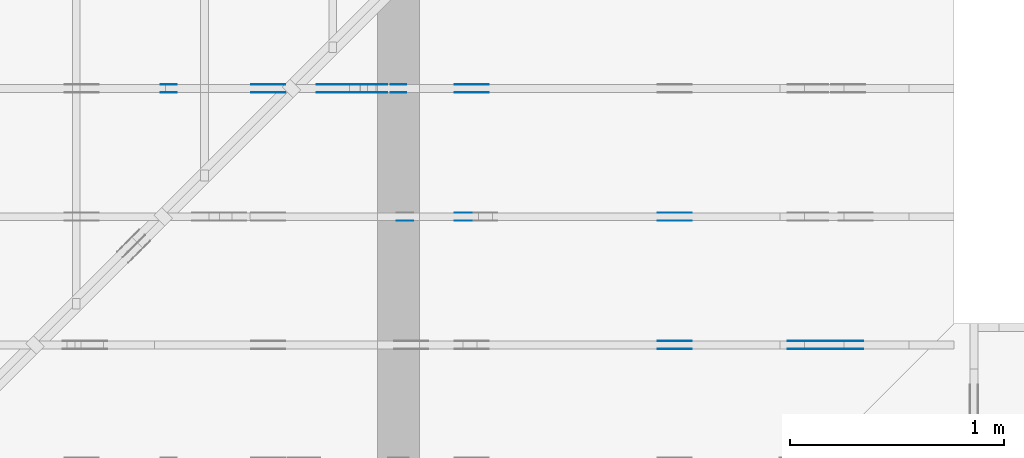
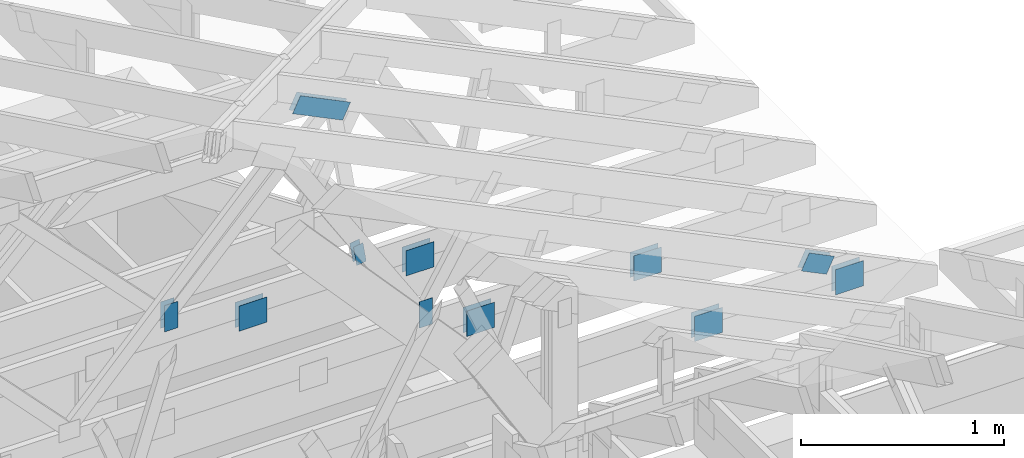
# One storey, part 133 of 159: 21 plates, 3 elements without a shape of their own.
"""IFC2X3 building model written with IfcOpenShell, lengths in millimetres."""

from ifc_helpers import new_model, si_unit, frame, origin, origin_with_axes, origin_2d, place, context, project, spatial, faceted_brep, element, aggregate, save


model = new_model("IFC2X3")

# Units and contexts
model_context = context("Model", 3, precision=1e-05, world=origin())
plan_context = context("Plan", 2, precision=1e-05, world=origin_2d())
ifc_project = project(units=[si_unit("LENGTHUNIT", "METRE", prefix="MILLI"), si_unit("AREAUNIT", "SQUARE_METRE"), si_unit("VOLUMEUNIT", "CUBIC_METRE"), si_unit("SOLIDANGLEUNIT", "STERADIAN"), si_unit("PLANEANGLEUNIT", "RADIAN"), si_unit("MASSUNIT", "GRAM"), si_unit("TIMEUNIT", "SECOND"), si_unit("THERMODYNAMICTEMPERATUREUNIT", "DEGREE_CELSIUS"), si_unit("LUMINOUSINTENSITYUNIT", "LUMEN")], contexts=[model_context, plan_context])

# Site, building, storey
site_placement = place(None, origin_with_axes())
site = spatial("IfcSite", under=ifc_project, at=site_placement, CompositionType="ELEMENT")
building_placement = place(site_placement, origin_with_axes())
building = spatial("IfcBuilding", under=site, at=building_placement, Name="Plan 1", CompositionType="ELEMENT")
storey_placement = place(building_placement, origin_with_axes())
storey = spatial("IfcBuildingStorey", under=building, at=storey_placement, Name="Etasje 1", CompositionType="ELEMENT", Elevation=0.0)

# Assembly, plates
assembly_1_placement = place(storey_placement, frame((19200.01266310149, 9617.999978540158, 1.1021457184401395e-15), z_axis=(1.2246063538223773e-16, 1.0, 6.123031769111886e-17), x_axis=(-1.0, 1.2246063538223773e-16, 0.0)))
assembly_1 = element("IfcElementAssembly", 1, at=assembly_1_placement, inside=storey, Name="V12 (104)", AssemblyPlace="FACTORY", PredefinedType="TRUSS")
plate_1_placement = place(assembly_1_placement, frame((634.5549831590021, 289.86159814155985, 0.0), z_axis=(0.0, 0.0, 1.0), x_axis=(0.8987940462991673, 0.4383711467890768, 0.0)))
plate_1 = element("IfcPlate", 2, at=plate_1_placement, Name="GNT100S 103x159", context=model_context, shape_type="Brep", body=[
    faceted_brep([(159.00002403271037, 102.9999867309898, 1.0), (1.1281355568826257e-05, 102.9999867309898, 1.0), (1.0588386885501677e-05, 0.0, 1.0), (159.0000233397417, 0.0, 1.0), (1.1281355568826257e-05, 102.9999867309898, 1.3815219709314093e-21), (159.00002403271037, 102.9999867309898, 1.947124396883678e-14), (159.0000233397417, 1.5107132753655605e-06, 1.9471243883975396e-14), (1.0588386885501677e-05, 1.5107132753655605e-06, 1.2966605856714886e-21), (159.0, 2.563772084510416e-06, 1.788345407099479e-30), (159.0, 2.5637720845716463e-06, 1.0), (1.1247455413666031e-32, 2.563772113778508e-06, 1.0), (0.0, 2.5637721137172775e-06, 0.0), (159.0, 103.00000256377206, 0.0), (159.0, 103.00000256377206, 1.0), (159.0, 2.5637721137172775e-06, 1.0), (159.0, 2.5637721137172775e-06, 0.0), (0.0, 103.00000256377206, 0.0), (-3.7491518045553436e-33, 103.00000256377206, 1.0), (159.0, 103.00000256377204, 1.0), (159.0, 103.00000256377204, -7.888609052210118e-31), (3.1396116202108044e-22, 2.5637721137172775e-06, -1.9223941693223597e-38), (6.123063165228088e-17, 2.5637721137172775e-06, 1.0), (1.2674676076022759e-14, 103.00000256377206, 1.0), (1.261344575833164e-14, 103.00000256377206, -7.723252909623421e-31)], [[[0, 1, 2, 3]], [[4, 5, 6, 7]], [[8, 9, 10, 11]], [[12, 13, 14, 15]], [[16, 17, 18, 19]], [[20, 21, 22, 23]]]),
])
plate_2_placement = place(assembly_1_placement, frame((634.5549831590021, 289.86159814155985, -37.0), z_axis=(0.0, 0.0, 1.0), x_axis=(0.8987940462991673, 0.4383711467890768, 0.0)))
plate_2 = element("IfcPlate", 3, at=plate_2_placement, Name="GNT100S 103x159", context=model_context, shape_type="Brep", body=[
    faceted_brep([(159.00002403271037, 102.9999867309898, 1.0), (1.1281355568826257e-05, 102.9999867309898, 1.0), (1.0588386885501677e-05, 0.0, 1.0), (159.0000233397417, 0.0, 1.0), (1.1281355568826257e-05, 102.9999867309898, 1.3815219709314093e-21), (159.00002403271037, 102.9999867309898, 1.947124396883678e-14), (159.0000233397417, 1.5107132753655605e-06, 1.9471243883975396e-14), (1.0588386885501677e-05, 1.5107132753655605e-06, 1.2966605856714886e-21), (159.0, 2.563772084510416e-06, 1.788345407099479e-30), (159.0, 2.5637720845716463e-06, 1.0), (1.1247455413666031e-32, 2.563772113778508e-06, 1.0), (0.0, 2.5637721137172775e-06, 0.0), (159.0, 103.00000256377206, 0.0), (159.0, 103.00000256377206, 1.0), (159.0, 2.5637721137172775e-06, 1.0), (159.0, 2.5637721137172775e-06, 0.0), (0.0, 103.00000256377206, 0.0), (-3.7491518045553436e-33, 103.00000256377206, 1.0), (159.0, 103.00000256377204, 1.0), (159.0, 103.00000256377204, -7.888609052210118e-31), (3.1396116202108044e-22, 2.5637721137172775e-06, -1.9223941693223597e-38), (6.123063165228088e-17, 2.5637721137172775e-06, 1.0), (1.2674676076022759e-14, 103.00000256377206, 1.0), (1.261344575833164e-14, 103.00000256377206, -7.723252909623421e-31)], [[[0, 1, 2, 3]], [[4, 5, 6, 7]], [[8, 9, 10, 11]], [[12, 13, 14, 15]], [[16, 17, 18, 19]], [[20, 21, 22, 23]]]),
])
plate_3_placement = place(assembly_1_placement, frame((1226.5269234454372, 147.0, 0.0), z_axis=(0.0, 0.0, 1.0), x_axis=(1.0, 0.0, 0.0)))
plate_3 = element("IfcPlate", 4, at=plate_3_placement, Name="GNT100S 152x159", context=model_context, shape_type="Brep", body=[
    faceted_brep([(159.0000540936253, 152.0, 1.0), (5.409362529462669e-05, 152.0, 1.0), (5.409362529462669e-05, 0.0, 1.0), (159.0000540936253, 0.0, 1.0), (5.409362529462669e-05, 152.0, 6.624339723708671e-21), (159.0000540936253, 152.0, 1.9471247650115523e-14), (159.0000540936253, 0.0, 1.9471247650115523e-14), (5.409362529462669e-05, 0.0, 6.624339723708671e-21), (159.0, 7.024986068391876e-10, 1.788345410772899e-30), (159.0, 7.024986680695053e-10, 1.0), (1.1247455413666031e-32, 7.025278749310439e-10, 1.0), (0.0, 7.025278137007263e-10, 0.0), (159.0, 152.00000000070253, 0.0), (159.0, 152.00000000070253, 1.0), (159.0, 7.025278137007263e-10, 1.0), (159.0, 7.025278137007263e-10, 0.0), (0.0, 152.00000000070253, 0.0), (-3.7491518045553436e-33, 152.00000000070253, 1.0), (159.0, 152.00000000070253, 1.0), (159.0, 152.00000000070253, 0.0), (8.603200243948527e-26, 7.025278137007263e-10, -5.267766840972796e-42), (6.123031777715086e-17, 7.025278137007263e-10, 1.0), (1.8675246895877286e-14, 152.00000000070253, 1.0), (1.8614016578186167e-14, 152.00000000070253, -1.1397421485900923e-30)], [[[0, 1, 2, 3]], [[4, 5, 6, 7]], [[8, 9, 10, 11]], [[12, 13, 14, 15]], [[16, 17, 18, 19]], [[20, 21, 22, 23]]]),
])
plate_4_placement = place(assembly_1_placement, frame((1226.5269234454372, 147.0, -37.0), z_axis=(0.0, 0.0, 1.0), x_axis=(1.0, 0.0, 0.0)))
plate_4 = element("IfcPlate", 5, at=plate_4_placement, Name="GNT100S 152x159", context=model_context, shape_type="Brep", body=[
    faceted_brep([(159.0000540936253, 152.0, 1.0), (5.409362529462669e-05, 152.0, 1.0), (5.409362529462669e-05, 0.0, 1.0), (159.0000540936253, 0.0, 1.0), (5.409362529462669e-05, 152.0, 6.624339723708671e-21), (159.0000540936253, 152.0, 1.9471247650115523e-14), (159.0000540936253, 0.0, 1.9471247650115523e-14), (5.409362529462669e-05, 0.0, 6.624339723708671e-21), (159.0, 7.024986068391876e-10, 1.788345410772899e-30), (159.0, 7.024986680695053e-10, 1.0), (1.1247455413666031e-32, 7.025278749310439e-10, 1.0), (0.0, 7.025278137007263e-10, 0.0), (159.0, 152.00000000070253, 0.0), (159.0, 152.00000000070253, 1.0), (159.0, 7.025278137007263e-10, 1.0), (159.0, 7.025278137007263e-10, 0.0), (0.0, 152.00000000070253, 0.0), (-3.7491518045553436e-33, 152.00000000070253, 1.0), (159.0, 152.00000000070253, 1.0), (159.0, 152.00000000070253, 0.0), (8.603200243948527e-26, 7.025278137007263e-10, -5.267766840972796e-42), (6.123031777715086e-17, 7.025278137007263e-10, 1.0), (1.8675246895877286e-14, 152.00000000070253, 1.0), (1.8614016578186167e-14, 152.00000000070253, -1.1397421485900923e-30)], [[[0, 1, 2, 3]], [[4, 5, 6, 7]], [[8, 9, 10, 11]], [[12, 13, 14, 15]], [[16, 17, 18, 19]], [[20, 21, 22, 23]]]),
])
plate_5_placement = place(assembly_1_placement, frame((424.1423839298536, 147.0, 0.0), z_axis=(0.0, 0.0, 1.0), x_axis=(1.0, 0.0, 0.0)))
plate_5 = element("IfcPlate", 6, at=plate_5_placement, Name="GNT100S 152x159", context=model_context, shape_type="Brep", body=[
    faceted_brep([(159.00001108967763, 152.0, 1.0), (1.1089677627751371e-05, 152.0, 1.0), (1.1089677627751371e-05, 0.0, 1.0), (159.00001108967763, 0.0, 1.0), (1.1089677627751371e-05, 152.0, 1.3580489684786197e-21), (159.00001108967763, 152.0, 1.947124238382477e-14), (159.00001108967763, 0.0, 1.947124238382477e-14), (1.1089677627751371e-05, 0.0, 1.3580489684786197e-21), (159.0, 8.732846588064853e-10, 1.788345410772899e-30), (159.0, 8.73284720036803e-10, 1.0), (1.1247455413666031e-32, 8.733139268983416e-10, 1.0), (0.0, 8.733138656680239e-10, 0.0), (159.0, 152.00000000087334, 0.0), (159.0, 152.00000000087334, 1.0), (159.0, 8.733138656680239e-10, 1.0), (159.0, 8.733138656680239e-10, 0.0), (0.0, 152.00000000087334, 0.0), (-3.7491518045553436e-33, 152.00000000087334, 1.0), (159.0, 152.00000000087334, 1.0), (159.0, 152.00000000087334, 0.0), (1.0694657087782442e-25, 8.733138656680239e-10, -6.54837251082495e-42), (6.123031779806544e-17, 8.733138656680239e-10, 1.0), (1.8675246895898204e-14, 152.00000000087334, 1.0), (1.8614016578207085e-14, 152.00000000087334, -1.139742148591373e-30)], [[[0, 1, 2, 3]], [[4, 5, 6, 7]], [[8, 9, 10, 11]], [[12, 13, 14, 15]], [[16, 17, 18, 19]], [[20, 21, 22, 23]]]),
])
plate_6_placement = place(assembly_1_placement, frame((424.1423839298536, 147.0, -37.0), z_axis=(0.0, 0.0, 1.0), x_axis=(1.0, 0.0, 0.0)))
plate_6 = element("IfcPlate", 7, at=plate_6_placement, Name="GNT100S 152x159", context=model_context, shape_type="Brep", body=[
    faceted_brep([(159.00001108967763, 152.0, 1.0), (1.1089677627751371e-05, 152.0, 1.0), (1.1089677627751371e-05, 0.0, 1.0), (159.00001108967763, 0.0, 1.0), (1.1089677627751371e-05, 152.0, 1.3580489684786197e-21), (159.00001108967763, 152.0, 1.947124238382477e-14), (159.00001108967763, 0.0, 1.947124238382477e-14), (1.1089677627751371e-05, 0.0, 1.3580489684786197e-21), (159.0, 8.732846588064853e-10, 1.788345410772899e-30), (159.0, 8.73284720036803e-10, 1.0), (1.1247455413666031e-32, 8.733139268983416e-10, 1.0), (0.0, 8.733138656680239e-10, 0.0), (159.0, 152.00000000087334, 0.0), (159.0, 152.00000000087334, 1.0), (159.0, 8.733138656680239e-10, 1.0), (159.0, 8.733138656680239e-10, 0.0), (0.0, 152.00000000087334, 0.0), (-3.7491518045553436e-33, 152.00000000087334, 1.0), (159.0, 152.00000000087334, 1.0), (159.0, 152.00000000087334, 0.0), (1.0694657087782442e-25, 8.733138656680239e-10, -6.54837251082495e-42), (6.123031779806544e-17, 8.733138656680239e-10, 1.0), (1.8675246895898204e-14, 152.00000000087334, 1.0), (1.8614016578207085e-14, 152.00000000087334, -1.139742148591373e-30)], [[[0, 1, 2, 3]], [[4, 5, 6, 7]], [[8, 9, 10, 11]], [[12, 13, 14, 15]], [[16, 17, 18, 19]], [[20, 21, 22, 23]]]),
])
aggregate(assembly_1, [plate_1, plate_2, plate_3, plate_4, plate_5, plate_6])

assembly_2_placement = place(storey_placement, frame((19200.01266310149, 10817.999978540158, 1.1021457184401395e-15), z_axis=(1.2246063538223773e-16, 1.0, 6.123031769111886e-17), x_axis=(-1.0, 1.2246063538223773e-16, 0.0)))
assembly_2 = element("IfcElementAssembly", 8, at=assembly_2_placement, inside=storey, Name="V10 (59)", AssemblyPlace="FACTORY", PredefinedType="TRUSS")
plate_7_placement = place(assembly_2_placement, frame((3712.277587890625, 291.5, 0.0), z_axis=(0.0, 0.0, 1.0), x_axis=(6.123031769111886e-17, 1.0, 0.0)))
plate_7 = element("IfcPlate", 9, at=plate_7_placement, Name="GNT100S 76x159", context=model_context, shape_type="Brep", body=[
    faceted_brep([(159.0, 76.0, 1.0), (0.0, 76.0, 1.0), (0.0, 0.0, 1.0), (159.0, 0.0, 1.0), (0.0, 76.0, 0.0), (159.0, 76.0, 1.9471241025775798e-14), (159.0, 0.0, 1.9471241025775798e-14), (0.0, 0.0, 0.0), (159.00000000027148, 0.00010246123244349903, 1.788345571668688e-30), (159.00000000027148, 0.00010246123244356026, 1.0), (2.714841684792191e-10, 0.00010246123247276712, 1.0), (2.714841684792191e-10, 0.00010246123247270589, 0.0), (159.00000000027148, 76.00010246123247, 0.0), (159.00000000027148, 76.00010246123247, 1.0), (159.00000000027148, 0.00010246123247270589, 1.0), (159.00000000027148, 0.00010246123247270589, 0.0), (2.714841684792191e-10, 76.00010246123247, 0.0), (2.714841684792191e-10, 76.00010246123247, 1.0), (159.00000000027148, 76.00010246123246, 1.0), (159.00000000027148, 76.00010246123246, -7.888609052210118e-31), (2.7148416849176653e-10, 0.00010246123247270589, -7.682842814207347e-37), (2.714842297220842e-10, 0.00010246123247270589, 1.0), (2.7149353673037327e-10, 76.00010246123247, 1.0), (2.714934755000556e-10, 76.00010246123247, -5.6987184257669365e-31)], [[[0, 1, 2, 3]], [[4, 5, 6, 7]], [[8, 9, 10, 11]], [[12, 13, 14, 15]], [[16, 17, 18, 19]], [[20, 21, 22, 23]]]),
])
plate_8_placement = place(assembly_2_placement, frame((3712.277587890625, 291.5, -37.0), z_axis=(0.0, 0.0, 1.0), x_axis=(6.123031769111886e-17, 1.0, 0.0)))
plate_8 = element("IfcPlate", 10, at=plate_8_placement, Name="GNT100S 76x159", context=model_context, shape_type="Brep", body=[
    faceted_brep([(159.0, 76.0, 1.0), (0.0, 76.0, 1.0), (0.0, 0.0, 1.0), (159.0, 0.0, 1.0), (0.0, 76.0, 0.0), (159.0, 76.0, 1.9471241025775798e-14), (159.0, 0.0, 1.9471241025775798e-14), (0.0, 0.0, 0.0), (159.00000000027148, 0.00010246123244349903, 1.788345571668688e-30), (159.00000000027148, 0.00010246123244356026, 1.0), (2.714841684792191e-10, 0.00010246123247276712, 1.0), (2.714841684792191e-10, 0.00010246123247270589, 0.0), (159.00000000027148, 76.00010246123247, 0.0), (159.00000000027148, 76.00010246123247, 1.0), (159.00000000027148, 0.00010246123247270589, 1.0), (159.00000000027148, 0.00010246123247270589, 0.0), (2.714841684792191e-10, 76.00010246123247, 0.0), (2.714841684792191e-10, 76.00010246123247, 1.0), (159.00000000027148, 76.00010246123246, 1.0), (159.00000000027148, 76.00010246123246, -7.888609052210118e-31), (2.7148416849176653e-10, 0.00010246123247270589, -7.682842814207347e-37), (2.714842297220842e-10, 0.00010246123247270589, 1.0), (2.7149353673037327e-10, 76.00010246123247, 1.0), (2.714934755000556e-10, 76.00010246123247, -5.6987184257669365e-31)], [[[0, 1, 2, 3]], [[4, 5, 6, 7]], [[8, 9, 10, 11]], [[12, 13, 14, 15]], [[16, 17, 18, 19]], [[20, 21, 22, 23]]]),
])
plate_9_placement = place(assembly_2_placement, frame((3129.175537109375, 147.0, 0.0), z_axis=(0.0, 0.0, 1.0), x_axis=(1.0, 0.0, 0.0)))
plate_9 = element("IfcPlate", 11, at=plate_9_placement, Name="GNT100S 152x159", context=model_context, shape_type="Brep", body=[
    faceted_brep([(159.0, 152.0, 1.0), (0.0, 152.0, 1.0), (0.0, 0.0, 1.0), (159.0, 0.0, 1.0), (0.0, 152.0, 0.0), (159.0, 152.0, 1.9471241025775798e-14), (159.0, 0.0, 1.9471241025775798e-14), (0.0, 0.0, 0.0), (159.00010403888245, 8.447995707195087e-14, 1.7883465809455904e-30), (159.00010403888245, 8.454118738964198e-14, 1.0), (0.00010403888245491544, 1.1374804892830568e-13, 1.0), (0.00010403888245491544, 1.1368681861061455e-13, 1.1701726914923643e-36), (159.00010403888245, 152.0000000000001, 0.0), (159.00010403888245, 152.0000000000001, 1.0), (159.00010403888245, 1.1368683772161603e-13, 1.0), (159.00010403888245, 1.1368683772161603e-13, 0.0), (0.00010403888245491544, 152.0000000000001, 0.0), (0.00010403888245491544, 152.0000000000001, 1.0), (159.00010403888245, 152.0000000000001, 1.0), (159.00010403888245, 152.0000000000001, 0.0), (0.00010403888245491544, 1.1368683772161603e-13, 0.0), (0.00010403888245497667, 1.1368683772161603e-13, 1.0), (0.00010403888247359068, 152.0000000000001, 1.0), (0.00010403888247352945, 152.0000000000001, -1.1397420192804459e-30)], [[[0, 1, 2, 3]], [[4, 5, 6, 7]], [[8, 9, 10, 11]], [[12, 13, 14, 15]], [[16, 17, 18, 19]], [[20, 21, 22, 23]]]),
])
plate_10_placement = place(assembly_2_placement, frame((3129.175537109375, 147.0, -37.0), z_axis=(0.0, 0.0, 1.0), x_axis=(1.0, 0.0, 0.0)))
plate_10 = element("IfcPlate", 12, at=plate_10_placement, Name="GNT100S 152x159", context=model_context, shape_type="Brep", body=[
    faceted_brep([(159.0, 152.0, 1.0), (0.0, 152.0, 1.0), (0.0, 0.0, 1.0), (159.0, 0.0, 1.0), (0.0, 152.0, 0.0), (159.0, 152.0, 1.9471241025775798e-14), (159.0, 0.0, 1.9471241025775798e-14), (0.0, 0.0, 0.0), (159.00010403888245, 8.447995707195087e-14, 1.7883465809455904e-30), (159.00010403888245, 8.454118738964198e-14, 1.0), (0.00010403888245491544, 1.1374804892830568e-13, 1.0), (0.00010403888245491544, 1.1368681861061455e-13, 1.1701726914923643e-36), (159.00010403888245, 152.0000000000001, 0.0), (159.00010403888245, 152.0000000000001, 1.0), (159.00010403888245, 1.1368683772161603e-13, 1.0), (159.00010403888245, 1.1368683772161603e-13, 0.0), (0.00010403888245491544, 152.0000000000001, 0.0), (0.00010403888245491544, 152.0000000000001, 1.0), (159.00010403888245, 152.0000000000001, 1.0), (159.00010403888245, 152.0000000000001, 0.0), (0.00010403888245491544, 1.1368683772161603e-13, 0.0), (0.00010403888245497667, 1.1368683772161603e-13, 1.0), (0.00010403888247359068, 152.0000000000001, 1.0), (0.00010403888247352945, 152.0000000000001, -1.1397420192804459e-30)], [[[0, 1, 2, 3]], [[4, 5, 6, 7]], [[8, 9, 10, 11]], [[12, 13, 14, 15]], [[16, 17, 18, 19]], [[20, 21, 22, 23]]]),
])
plate_11_placement = place(assembly_2_placement, frame((2177.8512822965154, 147.0, 0.0), z_axis=(0.0, 0.0, 1.0), x_axis=(1.0, 0.0, 0.0)))
plate_11 = element("IfcPlate", 13, at=plate_11_placement, Name="GNT100S 152x159", context=model_context, shape_type="Brep", body=[
    faceted_brep([(159.00003606285964, 152.0, 1.0), (3.6062859635421773e-05, 152.0, 1.0), (3.6062859635421773e-05, 0.0, 1.0), (159.00003606285964, 0.0, 1.0), (3.6062859635421773e-05, 152.0, 4.416280704654204e-21), (159.00003606285964, 152.0, 1.9471245442056505e-14), (159.00003606285964, 0.0, 1.9471245442056505e-14), (3.6062859635421773e-05, 0.0, 4.416280704654204e-21), (159.0, 1.9816681390456836e-13, 1.788345410772899e-30), (159.0, 1.9822804422225948e-13, 1.0), (1.1247455413666031e-32, 2.274349057609232e-13, 1.0), (0.0, 2.2737367544323206e-13, 0.0), (159.0, 152.00000000000023, 0.0), (159.0, 152.00000000000023, 1.0), (159.0, 2.2737367544323206e-13, 1.0), (159.0, 2.2737367544323206e-13, 0.0), (0.0, 152.00000000000023, 0.0), (-3.7491518045553436e-33, 152.00000000000023, 1.0), (159.0, 152.00000000000023, 1.0), (159.0, 152.00000000000023, 0.0), (2.78443247639729e-29, 2.2737367544323206e-13, -1.704916851192749e-45), (6.123031769114671e-17, 2.2737367544323206e-13, 1.0), (1.8675246895791282e-14, 152.00000000000023, 1.0), (1.8614016578100163e-14, 152.00000000000023, -1.1397421485848262e-30)], [[[0, 1, 2, 3]], [[4, 5, 6, 7]], [[8, 9, 10, 11]], [[12, 13, 14, 15]], [[16, 17, 18, 19]], [[20, 21, 22, 23]]]),
])
plate_12_placement = place(assembly_2_placement, frame((2177.8512822965154, 147.0, -37.0), z_axis=(0.0, 0.0, 1.0), x_axis=(1.0, 0.0, 0.0)))
plate_12 = element("IfcPlate", 14, at=plate_12_placement, Name="GNT100S 152x159", context=model_context, shape_type="Brep", body=[
    faceted_brep([(159.00003606285964, 152.0, 1.0), (3.6062859635421773e-05, 152.0, 1.0), (3.6062859635421773e-05, 0.0, 1.0), (159.00003606285964, 0.0, 1.0), (3.6062859635421773e-05, 152.0, 4.416280704654204e-21), (159.00003606285964, 152.0, 1.9471245442056505e-14), (159.00003606285964, 0.0, 1.9471245442056505e-14), (3.6062859635421773e-05, 0.0, 4.416280704654204e-21), (159.0, 1.9816681390456836e-13, 1.788345410772899e-30), (159.0, 1.9822804422225948e-13, 1.0), (1.1247455413666031e-32, 2.274349057609232e-13, 1.0), (0.0, 2.2737367544323206e-13, 0.0), (159.0, 152.00000000000023, 0.0), (159.0, 152.00000000000023, 1.0), (159.0, 2.2737367544323206e-13, 1.0), (159.0, 2.2737367544323206e-13, 0.0), (0.0, 152.00000000000023, 0.0), (-3.7491518045553436e-33, 152.00000000000023, 1.0), (159.0, 152.00000000000023, 1.0), (159.0, 152.00000000000023, 0.0), (2.78443247639729e-29, 2.2737367544323206e-13, -1.704916851192749e-45), (6.123031769114671e-17, 2.2737367544323206e-13, 1.0), (1.8675246895791282e-14, 152.00000000000023, 1.0), (1.8614016578100163e-14, 152.00000000000023, -1.1397421485848262e-30)], [[[0, 1, 2, 3]], [[4, 5, 6, 7]], [[8, 9, 10, 11]], [[12, 13, 14, 15]], [[16, 17, 18, 19]], [[20, 21, 22, 23]]]),
])
plate_13_placement = place(assembly_2_placement, frame((2616.9270014582316, 307.9514128672783, 0.0), z_axis=(0.0, 0.0, 1.0), x_axis=(0.15528482829789167, 0.9878697394396158, 0.0)))
plate_13 = element("IfcPlate", 15, at=plate_13_placement, Name="GNT100S 55x119", context=model_context, shape_type="Brep", body=[
    faceted_brep([(118.99999681199449, 54.99993110830155, 1.0), (2.856797584627202e-05, 54.99993110830155, 1.0), (3.187005972904444e-06, 0.0, 1.0), (118.9999714310245, 0.0, 1.0), (2.856797584627202e-05, 54.99993110830155, 3.498452473718892e-21), (118.99999681199449, 54.99993110830155, 1.457281522008111e-14), (118.9999714310245, 0.00013146531046004384, 1.45728121119114e-14), (3.187005972904444e-06, 0.00013146531046004384, 3.9028277640886495e-22), (119.0, 3.128683330134825e-05, -6.193568767815915e-31), (119.0, 3.128683330140948e-05, 1.0), (2.287764032688988e-31, 3.128683374604163e-05, 1.0), (0.0, 3.12868337459804e-05, 0.0), (119.0, 55.000031286833746, 0.0), (119.0, 55.000031286833746, 1.0), (119.0, 3.128683329123305e-05, 1.0), (119.0, 3.128683329123305e-05, 0.0), (0.0, 55.000031286833746, 0.0), (-3.7491518045553436e-33, 55.000031286833746, 1.0), (119.0, 55.00003128683374, 1.0), (119.0, 55.00003128683374, -3.944304526105059e-31), (3.831405539631197e-21, 3.12868337459804e-05, -2.345981783951309e-37), (6.12341490966585e-17, 3.12868337459804e-05, 1.0), (6.796569095119733e-15, 55.000031286833746, 1.0), (6.7353387774286145e-15, 55.000031286833746, -4.124069330992662e-31)], [[[0, 1, 2, 3]], [[4, 5, 6, 7]], [[8, 9, 10, 11]], [[12, 13, 14, 15]], [[16, 17, 18, 19]], [[20, 21, 22, 23]]]),
])
plate_14_placement = place(assembly_2_placement, frame((2616.9270014582316, 307.9514128672783, -37.0), z_axis=(0.0, 0.0, 1.0), x_axis=(0.15528482829789167, 0.9878697394396158, 0.0)))
plate_14 = element("IfcPlate", 16, at=plate_14_placement, Name="GNT100S 55x119", context=model_context, shape_type="Brep", body=[
    faceted_brep([(118.99999681199449, 54.99993110830155, 1.0), (2.856797584627202e-05, 54.99993110830155, 1.0), (3.187005972904444e-06, 0.0, 1.0), (118.9999714310245, 0.0, 1.0), (2.856797584627202e-05, 54.99993110830155, 3.498452473718892e-21), (118.99999681199449, 54.99993110830155, 1.457281522008111e-14), (118.9999714310245, 0.00013146531046004384, 1.45728121119114e-14), (3.187005972904444e-06, 0.00013146531046004384, 3.9028277640886495e-22), (119.0, 3.128683330134825e-05, -6.193568767815915e-31), (119.0, 3.128683330140948e-05, 1.0), (2.287764032688988e-31, 3.128683374604163e-05, 1.0), (0.0, 3.12868337459804e-05, 0.0), (119.0, 55.000031286833746, 0.0), (119.0, 55.000031286833746, 1.0), (119.0, 3.128683329123305e-05, 1.0), (119.0, 3.128683329123305e-05, 0.0), (0.0, 55.000031286833746, 0.0), (-3.7491518045553436e-33, 55.000031286833746, 1.0), (119.0, 55.00003128683374, 1.0), (119.0, 55.00003128683374, -3.944304526105059e-31), (3.831405539631197e-21, 3.12868337459804e-05, -2.345981783951309e-37), (6.12341490966585e-17, 3.12868337459804e-05, 1.0), (6.796569095119733e-15, 55.000031286833746, 1.0), (6.7353387774286145e-15, 55.000031286833746, -4.124069330992662e-31)], [[[0, 1, 2, 3]], [[4, 5, 6, 7]], [[8, 9, 10, 11]], [[12, 13, 14, 15]], [[16, 17, 18, 19]], [[20, 21, 22, 23]]]),
])
plate_15_placement = place(assembly_2_placement, frame((2697.3187616910254, 1211.9372139313334, 0.0), z_axis=(0.0, 0.0, 1.0), x_axis=(0.8987940462991675, 0.43837114678907646, 0.0)))
plate_15 = element("IfcPlate", 17, at=plate_15_placement, Name="GNT100S 103x317", context=model_context, shape_type="Brep", body=[
    faceted_brep([(316.99999736103564, 103.00006767211039, 1.0), (0.0, 103.00006767211039, 1.0), (9.564507581671933e-05, 0.0, 1.0), (317.000146518214, 0.0, 1.0), (0.0, 103.00006767211039, 0.0), (316.99999736103564, 103.00006767211039, 3.882002109300011e-14), (317.000146518214, 7.70852172990999e-05, 3.8820039358882946e-14), (9.564507581671933e-05, 7.70852172990999e-05, 1.1712756755697749e-20), (317.00008318309256, 5.200521326148681e-05, 3.565444389546901e-30), (317.00008318309256, 5.200521326154804e-05, 1.0), (8.318309255628265e-05, 5.2005213319778075e-05, 1.0), (8.318309255628265e-05, 5.2005213319716845e-05, 7.52316384526264e-37), (317.00008318309256, 103.00005200521309, 0.0), (317.00008318309256, 103.00005200521309, 1.0), (317.00008318309256, 5.200521331971686e-05, 1.0), (317.00008318309256, 5.200521331971686e-05, 0.0), (8.318309255628265e-05, 103.00005200521332, 0.0), (8.318309255628265e-05, 103.00005200521332, 1.0), (317.00008318309256, 103.00005200521309, 1.0), (317.00008318309256, 103.00005200521309, -7.888609052210118e-31), (8.318309255628265e-05, 5.200521331971686e-05, -7.52316384526264e-37), (8.318309255634388e-05, 5.200521331971686e-05, 1.0), (8.318309256895732e-05, 103.00005200521332, 1.0), (8.318309256889609e-05, 103.00005200521332, -7.7232574340550905e-31)], [[[0, 1, 2, 3]], [[4, 5, 6, 7]], [[8, 9, 10, 11]], [[12, 13, 14, 15]], [[16, 17, 18, 19]], [[20, 21, 22, 23]]]),
])
plate_16_placement = place(assembly_2_placement, frame((2697.3187616910254, 1211.9372139313334, -37.0), z_axis=(0.0, 0.0, 1.0), x_axis=(0.8987940462991675, 0.43837114678907646, 0.0)))
plate_16 = element("IfcPlate", 18, at=plate_16_placement, Name="GNT100S 103x317", context=model_context, shape_type="Brep", body=[
    faceted_brep([(316.99999736103564, 103.00006767211039, 1.0), (0.0, 103.00006767211039, 1.0), (9.564507581671933e-05, 0.0, 1.0), (317.000146518214, 0.0, 1.0), (0.0, 103.00006767211039, 0.0), (316.99999736103564, 103.00006767211039, 3.882002109300011e-14), (317.000146518214, 7.70852172990999e-05, 3.8820039358882946e-14), (9.564507581671933e-05, 7.70852172990999e-05, 1.1712756755697749e-20), (317.00008318309256, 5.200521326148681e-05, 3.565444389546901e-30), (317.00008318309256, 5.200521326154804e-05, 1.0), (8.318309255628265e-05, 5.2005213319778075e-05, 1.0), (8.318309255628265e-05, 5.2005213319716845e-05, 7.52316384526264e-37), (317.00008318309256, 103.00005200521309, 0.0), (317.00008318309256, 103.00005200521309, 1.0), (317.00008318309256, 5.200521331971686e-05, 1.0), (317.00008318309256, 5.200521331971686e-05, 0.0), (8.318309255628265e-05, 103.00005200521332, 0.0), (8.318309255628265e-05, 103.00005200521332, 1.0), (317.00008318309256, 103.00005200521309, 1.0), (317.00008318309256, 103.00005200521309, -7.888609052210118e-31), (8.318309255628265e-05, 5.200521331971686e-05, -7.52316384526264e-37), (8.318309255634388e-05, 5.200521331971686e-05, 1.0), (8.318309256895732e-05, 103.00005200521332, 1.0), (8.318309256889609e-05, 103.00005200521332, -7.7232574340550905e-31)], [[[0, 1, 2, 3]], [[4, 5, 6, 7]], [[8, 9, 10, 11]], [[12, 13, 14, 15]], [[16, 17, 18, 19]], [[20, 21, 22, 23]]]),
])
aggregate(assembly_2, [plate_7, plate_8, plate_9, plate_10, plate_11, plate_12, plate_13, plate_14, plate_15, plate_16])

assembly_3_placement = place(storey_placement, frame((19200.01266310149, 10217.999978540158, 1.1021457184401395e-15), z_axis=(1.2246063538223773e-16, 1.0, 6.123031769111886e-17), x_axis=(-1.0, 1.2246063538223773e-16, 0.0)))
assembly_3 = element("IfcElementAssembly", 19, at=assembly_3_placement, inside=storey, Name="V11 (60)", AssemblyPlace="FACTORY", PredefinedType="TRUSS")
plate_17_placement = place(assembly_3_placement, frame((2607.000000000011, 291.5, -37.0), z_axis=(0.0, 0.0, 1.0), x_axis=(6.123031769111886e-17, 1.0, 0.0)))
plate_17 = element("IfcPlate", 20, at=plate_17_placement, Name="GNT100S 76x159", context=model_context, shape_type="Brep", body=[
    faceted_brep([(159.0, 76.00000000001091, 1.0), (0.0, 76.00000000001091, 1.0), (0.0, 1.0913936421275139e-11, 1.0), (159.0, 1.0913936421275139e-11, 1.0), (0.0, 76.00000000001091, 0.0), (159.0, 76.00000000001091, 1.9471241025775798e-14), (159.0, 1.0913936421275139e-11, 1.9471241025775798e-14), (0.0, 1.0913936421275139e-11, 0.0), (159.00000000000057, -2.9206861538663805e-14, 1.7883454107729052e-30), (159.00000000000057, -2.9145631220972686e-14, 1.0), (5.684341886080801e-13, 6.123031769101445e-17, 1.0), (5.684341886080801e-13, -1.0441621786489838e-28, 6.393438191972809e-45), (159.00000000000057, 76.0, 0.0), (159.00000000000057, 76.0, 1.0), (159.00000000000057, 0.0, 1.0), (159.00000000000057, 0.0, 0.0), (5.684341886080801e-13, 76.0, 0.0), (5.684341886080801e-13, 76.0, 1.0), (159.00000000000057, 75.99999999999999, 1.0), (159.00000000000057, 75.99999999999999, -7.888609052210118e-31), (5.684341886080801e-13, 0.0, 0.0), (5.684954189257713e-13, -7.498303609110687e-33, 1.0), (5.778024272148213e-13, 76.0, 1.0), (5.777411968971302e-13, 76.0, -5.698710742924122e-31)], [[[0, 1, 2, 3]], [[4, 5, 6, 7]], [[8, 9, 10, 11]], [[12, 13, 14, 15]], [[16, 17, 18, 19]], [[20, 21, 22, 23]]]),
])
plate_18_placement = place(assembly_3_placement, frame((2177.851282297024, 147.0, 0.0), z_axis=(0.0, 0.0, 1.0), x_axis=(1.0, 0.0, 0.0)))
plate_18 = element("IfcPlate", 21, at=plate_18_placement, Name="GNT100S 152x159", context=model_context, shape_type="Brep", body=[
    faceted_brep([(159.00003606235077, 152.0, 1.0), (3.606235077313613e-05, 152.0, 1.0), (3.606235077313613e-05, 0.0, 1.0), (159.00003606235077, 0.0, 1.0), (3.606235077313613e-05, 152.0, 4.4162183890553825e-21), (159.00003606235077, 152.0, 1.9471245441994188e-14), (159.00003606235077, 0.0, 1.9471245441994188e-14), (3.606235077313613e-05, 0.0, 4.4162183890553825e-21), (159.0, 1.9816681390456836e-13, 1.788345410772899e-30), (159.0, 1.9822804422225948e-13, 1.0), (1.1247455413666031e-32, 2.274349057609232e-13, 1.0), (0.0, 2.2737367544323206e-13, 0.0), (159.0, 152.00000000000023, 0.0), (159.0, 152.00000000000023, 1.0), (159.0, 2.2737367544323206e-13, 1.0), (159.0, 2.2737367544323206e-13, 0.0), (0.0, 152.00000000000023, 0.0), (-3.7491518045553436e-33, 152.00000000000023, 1.0), (159.0, 152.00000000000023, 1.0), (159.0, 152.00000000000023, 0.0), (2.78443247639729e-29, 2.2737367544323206e-13, -1.704916851192749e-45), (6.123031769114671e-17, 2.2737367544323206e-13, 1.0), (1.8675246895791282e-14, 152.00000000000023, 1.0), (1.8614016578100163e-14, 152.00000000000023, -1.1397421485848262e-30)], [[[0, 1, 2, 3]], [[4, 5, 6, 7]], [[8, 9, 10, 11]], [[12, 13, 14, 15]], [[16, 17, 18, 19]], [[20, 21, 22, 23]]]),
])
plate_19_placement = place(assembly_3_placement, frame((2177.851282297024, 147.0, -37.0), z_axis=(0.0, 0.0, 1.0), x_axis=(1.0, 0.0, 0.0)))
plate_19 = element("IfcPlate", 22, at=plate_19_placement, Name="GNT100S 152x159", context=model_context, shape_type="Brep", body=[
    faceted_brep([(159.00003606235077, 152.0, 1.0), (3.606235077313613e-05, 152.0, 1.0), (3.606235077313613e-05, 0.0, 1.0), (159.00003606235077, 0.0, 1.0), (3.606235077313613e-05, 152.0, 4.4162183890553825e-21), (159.00003606235077, 152.0, 1.9471245441994188e-14), (159.00003606235077, 0.0, 1.9471245441994188e-14), (3.606235077313613e-05, 0.0, 4.4162183890553825e-21), (159.0, 1.9816681390456836e-13, 1.788345410772899e-30), (159.0, 1.9822804422225948e-13, 1.0), (1.1247455413666031e-32, 2.274349057609232e-13, 1.0), (0.0, 2.2737367544323206e-13, 0.0), (159.0, 152.00000000000023, 0.0), (159.0, 152.00000000000023, 1.0), (159.0, 2.2737367544323206e-13, 1.0), (159.0, 2.2737367544323206e-13, 0.0), (0.0, 152.00000000000023, 0.0), (-3.7491518045553436e-33, 152.00000000000023, 1.0), (159.0, 152.00000000000023, 1.0), (159.0, 152.00000000000023, 0.0), (2.78443247639729e-29, 2.2737367544323206e-13, -1.704916851192749e-45), (6.123031769114671e-17, 2.2737367544323206e-13, 1.0), (1.8675246895791282e-14, 152.00000000000023, 1.0), (1.8614016578100163e-14, 152.00000000000023, -1.1397421485848262e-30)], [[[0, 1, 2, 3]], [[4, 5, 6, 7]], [[8, 9, 10, 11]], [[12, 13, 14, 15]], [[16, 17, 18, 19]], [[20, 21, 22, 23]]]),
])
plate_20_placement = place(assembly_3_placement, frame((1226.5269234455363, 147.0, 0.0), z_axis=(0.0, 0.0, 1.0), x_axis=(1.0, 0.0, 0.0)))
plate_20 = element("IfcPlate", 23, at=plate_20_placement, Name="GNT100S 152x159", context=model_context, shape_type="Brep", body=[
    faceted_brep([(159.00005409352616, 152.0, 1.0), (5.40935261597042e-05, 152.0, 1.0), (5.40935261597042e-05, 0.0, 1.0), (159.00005409352616, 0.0, 1.0), (5.40935261597042e-05, 152.0, 6.624327583583074e-21), (159.00005409352616, 152.0, 1.947124765010338e-14), (159.00005409352616, 0.0, 1.947124765010338e-14), (5.40935261597042e-05, 0.0, 6.624327583583074e-21), (159.0, 3.118536516261844e-13, 1.788345410772899e-30), (159.0, 3.119148819438755e-13, 1.0), (1.1247455413666031e-32, 3.411217434825392e-13, 1.0), (0.0, 3.410605131648481e-13, 0.0), (159.0, 152.00000000000034, 0.0), (159.0, 152.00000000000034, 1.0), (159.0, 3.410605131648481e-13, 1.0), (159.0, 3.410605131648481e-13, 0.0), (4.861730685829017e-63, 152.00000000000034, 0.0), (-3.7491518045553436e-33, 152.00000000000034, 1.0), (159.0, 152.00000000000034, 1.0), (159.0, 152.00000000000034, 0.0), (4.176648714595935e-29, 3.410605131648481e-13, -2.5573752767891235e-45), (6.123031769116062e-17, 3.410605131648481e-13, 1.0), (1.8675246895791294e-14, 152.00000000000034, 1.0), (1.8614016578100175e-14, 152.00000000000034, -1.139742148584827e-30)], [[[0, 1, 2, 3]], [[4, 5, 6, 7]], [[8, 9, 10, 11]], [[12, 13, 14, 15]], [[16, 17, 18, 19]], [[20, 21, 22, 23]]]),
])
plate_21_placement = place(assembly_3_placement, frame((1226.5269234455363, 147.0, -37.0), z_axis=(0.0, 0.0, 1.0), x_axis=(1.0, 0.0, 0.0)))
plate_21 = element("IfcPlate", 24, at=plate_21_placement, Name="GNT100S 152x159", context=model_context, shape_type="Brep", body=[
    faceted_brep([(159.00005409352616, 152.0, 1.0), (5.40935261597042e-05, 152.0, 1.0), (5.40935261597042e-05, 0.0, 1.0), (159.00005409352616, 0.0, 1.0), (5.40935261597042e-05, 152.0, 6.624327583583074e-21), (159.00005409352616, 152.0, 1.947124765010338e-14), (159.00005409352616, 0.0, 1.947124765010338e-14), (5.40935261597042e-05, 0.0, 6.624327583583074e-21), (159.0, 3.118536516261844e-13, 1.788345410772899e-30), (159.0, 3.119148819438755e-13, 1.0), (1.1247455413666031e-32, 3.411217434825392e-13, 1.0), (0.0, 3.410605131648481e-13, 0.0), (159.0, 152.00000000000034, 0.0), (159.0, 152.00000000000034, 1.0), (159.0, 3.410605131648481e-13, 1.0), (159.0, 3.410605131648481e-13, 0.0), (4.861730685829017e-63, 152.00000000000034, 0.0), (-3.7491518045553436e-33, 152.00000000000034, 1.0), (159.0, 152.00000000000034, 1.0), (159.0, 152.00000000000034, 0.0), (4.176648714595935e-29, 3.410605131648481e-13, -2.5573752767891235e-45), (6.123031769116062e-17, 3.410605131648481e-13, 1.0), (1.8675246895791294e-14, 152.00000000000034, 1.0), (1.8614016578100175e-14, 152.00000000000034, -1.139742148584827e-30)], [[[0, 1, 2, 3]], [[4, 5, 6, 7]], [[8, 9, 10, 11]], [[12, 13, 14, 15]], [[16, 17, 18, 19]], [[20, 21, 22, 23]]]),
])
aggregate(assembly_3, [plate_17, plate_18, plate_19, plate_20, plate_21])

save(model, "model.ifc")
